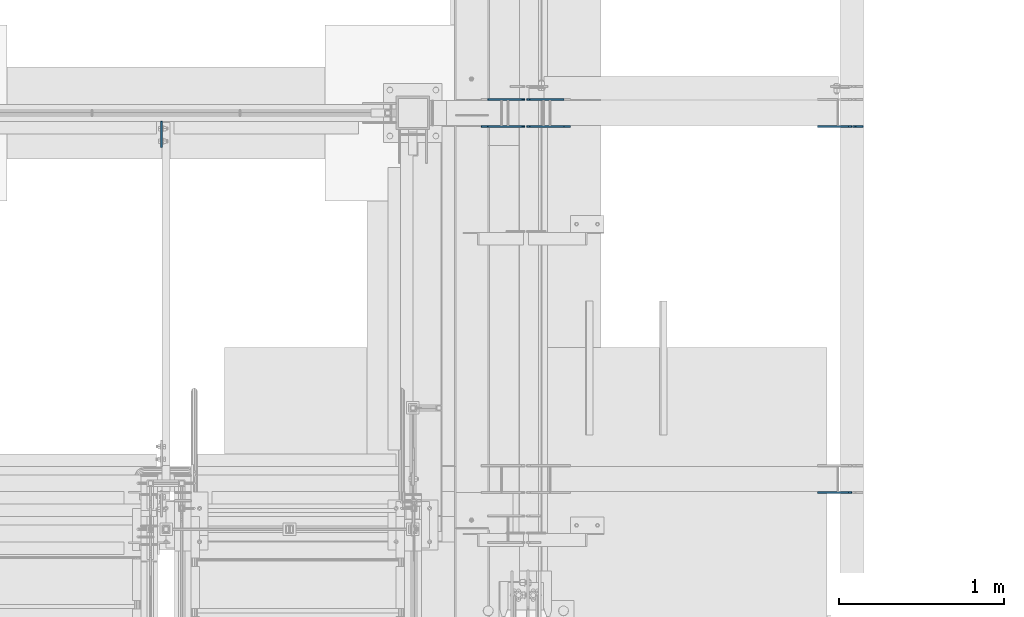
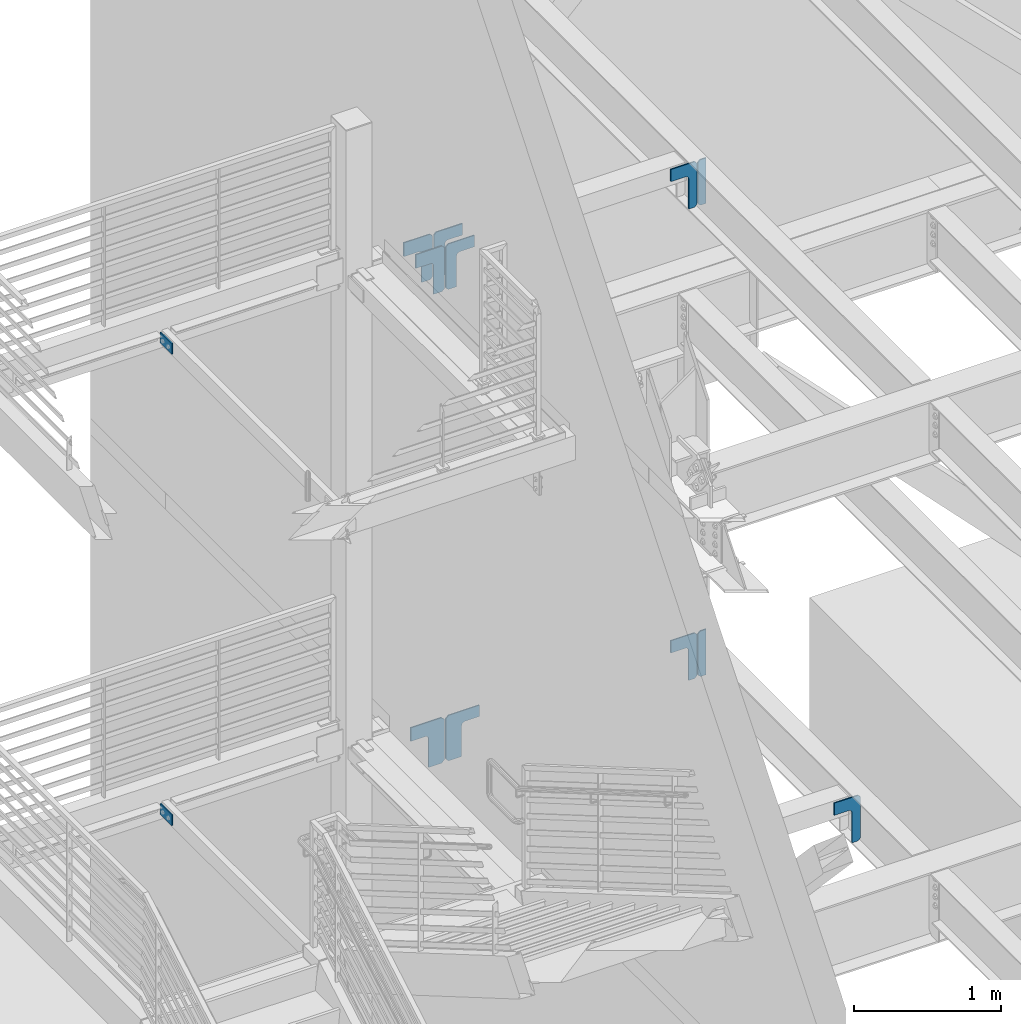
# One storey, part 1061 of 1179: 13 plates, 8 elements without a shape of their own.
"""IFC2X3 building model written with IfcOpenShell, lengths in millimetres."""

import ifcopenshell
import ifcopenshell.guid

model = None  # the IFC model being written
_history = None  # IfcOwnerHistory: only IFC2X3 demands one
_inside = {}  # id of a spatial element -> (the spatial element, [elements in it])
_under = {}  # id of a project, library or spatial element -> (it, [spatial elements below it])
_declared = {}  # id of a project -> (the project, [libraries it declares])
_typed = {}  # id of a type object -> (the type object, [elements of that type])
_made_of = {}  # id of a material, layer set ... -> (it, [elements and type objects made of it])


def new_model(schema):
    """Start an empty IFC model of exactly this schema.

    Asked for "IFC4X3", IfcOpenShell would pick the latest addendum, in which some entities
    have other attributes; the version numbers below select the first issue.
    IFC2X3 requires an IfcOwnerHistory on every rooted entity: one is made here for all.
    """
    global model, _history
    if schema == "IFC4X3":
        model = ifcopenshell.file(schema_version=(4, 3, 0, 0))
    else:
        model = ifcopenshell.file(schema=schema)
    _inside.clear()
    _under.clear()
    _declared.clear()
    _typed.clear()
    _made_of.clear()
    _history = None
    if model.schema == "IFC2X3":
        org = make("IfcOrganization", Name="unknown")
        user = make(
            "IfcPersonAndOrganization",
            ThePerson=make("IfcPerson", FamilyName="unknown"),
            TheOrganization=org,
        )
        app = make(
            "IfcApplication",
            ApplicationDeveloper=org,
            Version="unknown",
            ApplicationFullName="unknown",
            ApplicationIdentifier="unknown",
        )
        _history = make(
            "IfcOwnerHistory",
            OwningUser=user,
            OwningApplication=app,
            ChangeAction="ADDED",
            CreationDate=0,
        )
    return model


def make(cls, **values):
    """One entity of the class cls with the attributes given. An attribute that is None is left unset."""
    return model.create_entity(
        cls, **{name: value for name, value in values.items() if value is not None}
    )


def rooted(cls, **values):
    """An entity with a GlobalId (a new one), such as an element, a storey or a relation."""
    return make(cls, GlobalId=ifcopenshell.guid.new(), OwnerHistory=_history, **values)


def si_unit(unit_type, name, prefix=None):
    """IfcSIUnit, for example si_unit("LENGTHUNIT", "METRE", prefix="MILLI")."""
    return make("IfcSIUnit", UnitType=unit_type, Prefix=prefix, Name=name)


def assignment(units):
    """IfcUnitAssignment: the units of a project."""
    return None if units is None else make("IfcUnitAssignment", Units=units)


def point(xyz):
    """IfcCartesianPoint."""
    return None if xyz is None else make("IfcCartesianPoint", Coordinates=xyz)


def direction(xyz):
    """IfcDirection."""
    return None if xyz is None else make("IfcDirection", DirectionRatios=xyz)


def frame(location, z_axis=None, x_axis=None):
    """IfcAxis2Placement3D, a coordinate frame: its origin and axes. An axis left out is left unset."""
    return make(
        "IfcAxis2Placement3D",
        Location=point(location),
        Axis=direction(z_axis),
        RefDirection=direction(x_axis),
    )


def origin_with_axes():
    """The frame at (0, 0, 0) with the z axis (0, 0, 1) and the x axis (1, 0, 0) written out."""
    return frame((0.0, 0.0, 0.0), z_axis=(0.0, 0.0, 1.0), x_axis=(1.0, 0.0, 0.0))


def place(relative_to, where):
    """IfcLocalPlacement: puts the frame where relative to a parent placement (None: the world)."""
    return make(
        "IfcLocalPlacement", PlacementRelTo=relative_to, RelativePlacement=where
    )


def context(
    kind, dimensions, precision=None, world=None, true_north=None, identifier=None
):
    """IfcGeometricRepresentationContext, for example the 3D "Model" context."""
    return make(
        "IfcGeometricRepresentationContext",
        ContextIdentifier=identifier,
        ContextType=kind,
        CoordinateSpaceDimension=dimensions,
        Precision=precision,
        WorldCoordinateSystem=world,
        TrueNorth=true_north,
    )


def subcontext(parent, identifier, kind, view, scale=None):
    """IfcGeometricRepresentationSubContext, for example "Body" below "Model"."""
    return make(
        "IfcGeometricRepresentationSubContext",
        ContextIdentifier=identifier,
        ContextType=kind,
        ParentContext=parent,
        TargetScale=scale,
        TargetView=view,
    )


def project(units=None, contexts=None):
    """IfcProject with its units and contexts."""
    return rooted(
        "IfcProject",
        Name="project",
        RepresentationContexts=contexts,
        UnitsInContext=assignment(units),
    )


def spatial(cls, under=None, at=None, **own):
    """A site, building, storey or space (cls), placed at a placement, below another one or the project."""
    s = rooted(cls, ObjectPlacement=at, **own)
    if under is not None:
        _under.setdefault(under.id(), (under, []))[1].append(s)
    return s


def faces_of(points, faces, orient=None, outer=None):
    """IfcFace entities. A face is a list of loops; a loop is a list of indices into points, from 0.

    orient and outer hold one flag for each loop. By default every Orientation is true, the
    first loop of a face is its IfcFaceOuterBound and the others are IfcFaceBound.
    """
    made = []
    for i, loops in enumerate(faces):
        bounds = []
        for j, loop in enumerate(loops):
            is_outer = j == 0 if outer is None else outer[i][j]
            bounds.append(
                make(
                    "IfcFaceOuterBound" if is_outer else "IfcFaceBound",
                    Bound=make("IfcPolyLoop", Polygon=[points[k] for k in loop]),
                    Orientation=True if orient is None else orient[i][j],
                )
            )
        made.append(make("IfcFace", Bounds=bounds))
    return made


def faceted_brep(points, faces, orient=None, outer=None, voids=None):
    """IfcFacetedBrep: a solid bounded by flat faces; with voids (closed shells), ...WithVoids."""
    shared = [point(p) for p in points]
    hull = make("IfcClosedShell", CfsFaces=faces_of(shared, faces, orient, outer))
    if voids is None:
        return make("IfcFacetedBrep", Outer=hull)
    return make(
        "IfcFacetedBrepWithVoids",
        Outer=hull,
        Voids=[
            make(cls, CfsFaces=faces_of(shared, fs, o, b)) for cls, fs, o, b in voids
        ],
    )


def shape(context_of_items, identifier, shape_type, items):
    """IfcShapeRepresentation: the items that make up one representation, for example the "Body"."""
    return make(
        "IfcShapeRepresentation",
        ContextOfItems=context_of_items,
        RepresentationIdentifier=identifier,
        RepresentationType=shape_type,
        Items=items,
    )


def material(Name=None, Category=None):
    """IfcMaterial."""
    return make("IfcMaterial", Name=Name, Category=Category)


def made_of(thing, what):
    """Note that an element or type object is made of a material, layer set ...; save() writes the relation."""
    if what is not None:
        _made_of.setdefault(what.id(), (what, []))[1].append(thing)
    return thing


def type_object(cls, material=None, **own):
    """A type object (cls), such as IfcWallType, which elements share."""
    return made_of(rooted(cls, **own), material)


def element(
    cls,
    number,
    at=None,
    inside=None,
    cuts=None,
    type_object=None,
    material=None,
    context=None,
    identifier="Body",
    shape_type=None,
    held_by="IfcProductDefinitionShape",
    body=None,
    shapes=None,
    **own,
):
    """One element of the class cls, such as IfcWall. Its Tag is "e" and its number.

    at: its placement. inside: the storey or other place that contains it. cuts: it is an
    opening in that element (IfcRelVoidsElement). A single representation is given by context,
    identifier, shape_type and body (its items); several are given by shapes. held_by: the class
    of the entity that holds the representations. save() writes the other relations.
    """
    e = rooted(cls, Tag="e%d" % number, ObjectPlacement=at, **own)
    if body is not None:
        shapes = [shape(context, identifier, shape_type, body)]
    if shapes is not None:
        e.Representation = make(held_by, Representations=shapes)
    if inside is not None:
        _inside.setdefault(inside.id(), (inside, []))[1].append(e)
    if cuts is not None:
        rooted(
            "IfcRelVoidsElement", RelatingBuildingElement=cuts, RelatedOpeningElement=e
        )
    if type_object is not None:
        _typed.setdefault(type_object.id(), (type_object, []))[1].append(e)
    return made_of(e, material)


def aggregate(whole, parts):
    """IfcRelAggregates: a whole, such as a stair, and the parts it consists of."""
    return rooted("IfcRelAggregates", RelatingObject=whole, RelatedObjects=parts)


def save(model, path):
    """Write the relations noted so far, then the file.

    IfcRelAggregates (storeys below a building ...), IfcRelContainedInSpatialStructure (elements
    in a storey), IfcRelDefinesByType, IfcRelAssociatesMaterial and IfcRelDeclares: one each for
    every whole, place, type object, material and project.
    """
    for whole, parts in _under.values():
        aggregate(whole, parts)
    for where, things in _inside.values():
        rooted(
            "IfcRelContainedInSpatialStructure",
            RelatedElements=things,
            RelatingStructure=where,
        )
    for kind, things in _typed.values():
        rooted("IfcRelDefinesByType", RelatedObjects=things, RelatingType=kind)
    for what, things in _made_of.values():
        rooted("IfcRelAssociatesMaterial", RelatedObjects=things, RelatingMaterial=what)
    for by, libraries in _declared.values():
        rooted("IfcRelDeclares", RelatingContext=by, RelatedDefinitions=libraries)
    model.write(path)


model = new_model("IFC2X3")

# Units and contexts
model_context = context("Model", 3, precision=1e-05, world=origin_with_axes())
body_context = subcontext(model_context, "Body", "Model", "MODEL_VIEW")
ifc_project = project(units=[si_unit("LENGTHUNIT", "METRE", prefix="MILLI"), si_unit("AREAUNIT", "SQUARE_METRE"), si_unit("VOLUMEUNIT", "CUBIC_METRE"), si_unit("MASSUNIT", "GRAM", prefix="KILO"), si_unit("TIMEUNIT", "SECOND"), si_unit("PLANEANGLEUNIT", "RADIAN"), si_unit("SOLIDANGLEUNIT", "STERADIAN"), si_unit("THERMODYNAMICTEMPERATUREUNIT", "DEGREE_CELSIUS"), si_unit("LUMINOUSINTENSITYUNIT", "LUMEN")], contexts=[model_context])

# Site, building, storey
site_placement = place(None, origin_with_axes())
site = spatial("IfcSite", under=ifc_project, at=site_placement, CompositionType="ELEMENT")
building_placement = place(site_placement, origin_with_axes())
building = spatial("IfcBuilding", under=site, at=building_placement, Name="Undefined", CompositionType="ELEMENT")
storey_placement = place(building_placement, origin_with_axes())
storey = spatial("IfcBuildingStorey", under=building, at=storey_placement, Name="Undefined", CompositionType="ELEMENT", Elevation=0.0)

# Assembly, plate
assembly_1_placement = place(storey_placement, origin_with_axes())
assembly_1 = element("IfcElementAssembly", 1, at=assembly_1_placement, inside=storey, Name="BEAM", AssemblyPlace="NOTDEFINED", PredefinedType="RIGID_FRAME")
ifc_material = material(Name="STEEL/A36")
plate_type_1 = type_object("IfcPlateType", PredefinedType="NOTDEFINED")
plate_1_placement = place(assembly_1_placement, frame((-1781.175, 37592.0, 4114.8), z_axis=(0.0, -1.0, 0.0), x_axis=(0.0, 0.0, -1.0)))
plate_1 = element("IfcPlate", 2, at=plate_1_placement, type_object=plate_type_1, material=ifc_material, Name="PLATE", context=body_context, shape_type="Brep", body=[
    faceted_brep([(0.0, -4.76249999999709, 0.0), (0.0, -4.76250000000005, 158.75), (0.0, 4.76250000000005, 158.75), (0.0, 4.76249999999709, 0.0), (88.8999999999996, -4.76250000000005, 158.75), (88.8999999999996, 4.76250000000005, 158.75), (88.8999999999996, -4.76250000000005, 0.0), (88.8999999999996, 4.76250000000005, 0.0)], [[[0, 1, 2, 3]], [[1, 4, 5, 2]], [[4, 6, 7, 5]], [[6, 0, 3, 7]], [[5, 7, 3, 2]], [[6, 4, 1, 0]]]),
])
aggregate(assembly_1, [plate_1])

assembly_2_placement = place(storey_placement, origin_with_axes())
assembly_2 = element("IfcElementAssembly", 3, at=assembly_2_placement, inside=storey, Name="BEAM", AssemblyPlace="NOTDEFINED", PredefinedType="RIGID_FRAME")
plate_2_placement = place(assembly_2_placement, frame((-1781.175, 37592.0, 8026.4), z_axis=(0.0, -1.0, 0.0), x_axis=(0.0, 0.0, -1.0)))
plate_2 = element("IfcPlate", 4, at=plate_2_placement, type_object=plate_type_1, material=ifc_material, Name="PLATE", context=body_context, shape_type="Brep", body=[
    faceted_brep([(0.0, -4.76249999999709, 0.0), (0.0, -4.76250000000005, 158.75), (0.0, 4.76250000000005, 158.75), (0.0, 4.76249999999709, 0.0), (88.8999999999996, -4.76250000000005, 158.75), (88.8999999999996, 4.76250000000005, 158.75), (88.8999999999996, -4.76250000000005, 0.0), (88.8999999999996, 4.76250000000005, 0.0)], [[[0, 1, 2, 3]], [[1, 4, 5, 2]], [[4, 6, 7, 5]], [[6, 0, 3, 7]], [[5, 7, 3, 2]], [[6, 4, 1, 0]]]),
])
aggregate(assembly_2, [plate_2])

assembly_3_placement = place(storey_placement, origin_with_axes())
assembly_3 = element("IfcElementAssembly", 5, at=assembly_3_placement, inside=storey, Name="BEAM", AssemblyPlace="NOTDEFINED", PredefinedType="RIGID_FRAME")
plate_type_2 = type_object("IfcPlateType", PredefinedType="NOTDEFINED")
plate_3_placement = place(assembly_3_placement, frame((2481.2625, 37561.8375, 7623.175), z_axis=(0.0, 0.0, 1.0), x_axis=(-1.0, 0.0, 0.0)))
plate_3 = element("IfcPlate", 6, at=plate_3_placement, type_object=plate_type_2, material=ifc_material, Name="PLATE", context=body_context, shape_type="Brep", body=[
    faceted_brep([(0.0, -4.76249999999709, 0.0), (0.0, -4.76249999999709, 377.825012207031), (0.0, 4.76249999999709, 377.825012207031), (0.0, 4.76249999999709, 0.0), (46.0375022888184, -4.76249999999709, 377.825012207031), (46.0375022888184, 4.76249999999709, 377.825012207031), (65.0875015258789, -4.76249999999709, 358.775012969971), (65.0875015258789, 4.76249999999709, 358.775012969971), (65.0875015258789, -4.76249999999709, 19.0499992370605), (65.0875015258789, 4.76249999999709, 19.0499992370605), (46.0375022888184, -4.76249999999709, 0.0), (46.0375022888184, 4.76249999999709, 0.0)], [[[0, 1, 2, 3]], [[1, 4, 5, 2]], [[4, 6, 7, 5]], [[6, 8, 9, 7]], [[8, 10, 11, 9]], [[10, 0, 3, 11]], [[5, 7, 9, 11, 3, 2]], [[10, 8, 6, 4, 1, 0]]]),
])

assembly_4_placement = place(storey_placement, origin_with_axes())
assembly_4 = element("IfcElementAssembly", 7, at=assembly_4_placement, inside=storey, Name="BEAM", AssemblyPlace="NOTDEFINED", PredefinedType="RIGID_FRAME")
plate_4_placement = place(assembly_4_placement, frame((2481.26227437875, 37561.837550128, 3711.575), z_axis=(0.0, 0.0, 1.0), x_axis=(-1.0, 0.0, 0.0)))
plate_4 = element("IfcPlate", 8, at=plate_4_placement, type_object=plate_type_2, material=ifc_material, Name="PLATE", context=body_context, shape_type="Brep", body=[
    faceted_brep([(0.0, -4.76249999999709, 0.0), (0.0, -4.76249999999709, 377.825012207031), (0.0, 4.76249999999709, 377.825012207031), (0.0, 4.76249999999709, 0.0), (46.0375022888184, -4.76249999999709, 377.825012207031), (46.0375022888184, 4.76249999999709, 377.825012207031), (65.0875015258789, -4.76249999999709, 358.775012969971), (65.0875015258789, 4.76249999999709, 358.775012969971), (65.0875015258789, -4.76249999999709, 19.0499992370605), (65.0875015258789, 4.76249999999709, 19.0499992370605), (46.0375022888184, -4.76249999999709, 0.0), (46.0375022888184, 4.76249999999709, 0.0)], [[[0, 1, 2, 3]], [[1, 4, 5, 2]], [[4, 6, 7, 5]], [[6, 8, 9, 7]], [[8, 10, 11, 9]], [[10, 0, 3, 11]], [[5, 7, 9, 11, 3, 2]], [[10, 8, 6, 4, 1, 0]]]),
])

assembly_5_placement = place(storey_placement, origin_with_axes())
assembly_5 = element("IfcElementAssembly", 9, at=assembly_5_placement, inside=storey, Name="BEAM", AssemblyPlace="NOTDEFINED", PredefinedType="RIGID_FRAME")
plate_type_3 = type_object("IfcPlateType", PredefinedType="NOTDEFINED")
plate_5_placement = place(assembly_5_placement, frame((426.291860782883, 37561.8375048772, 7994.65), z_axis=(-1.0, 0.0, 0.0), x_axis=(0.0, 0.0, -1.0)))
plate_5 = element("IfcPlate", 10, at=plate_5_placement, type_object=plate_type_3, material=ifc_material, Name="PLATE", context=body_context, shape_type="Brep", body=[
    faceted_brep([(0.0, -4.76250000000073, 19.0499992370605), (5.15311512572225e-07, -4.76250000051368, 224.679358085698), (5.15311512572225e-07, 4.7624999994805, 224.679358085698), (0.0, 4.76250000000073, 19.0499992370605), (114.300004602274, -4.76250000051368, 224.679358106336), (114.300004602274, 4.7624999994805, 224.679358106337), (114.300004180656, -4.76250000025175, 110.379356465598), (114.300004180656, 4.76249999974243, 110.379356465598), (116.23346399875, -4.76250000022992, 100.659197401194), (116.23346399875, 4.76249999977153, 100.659197401194), (121.739491792959, -4.76250000021537, 92.4188444333355), (121.739491792959, 4.76249999978609, 92.4188444333356), (129.979844740076, -4.76250000020082, 86.9128166080852), (129.979844740076, 4.76249999980064, 86.9128166080853), (139.700003797197, -4.76250000019354, 84.9793567533749), (139.700003797197, 4.76249999980791, 84.979356753375), (377.825000000001, -4.76250000019354, 84.9793567347261), (377.825000000001, 4.76249999980791, 84.9793567347261), (377.825000000001, -4.76250000004802, 19.0499992370604), (377.825000000001, 4.76249999995343, 19.0499992370605), (358.77500076294, -4.76249999999709, -5.6843418860808e-14), (358.77500076294, 4.76249999999709, 0.0), (19.0499992370605, -4.76250000000073, 0.0), (19.0499992370605, 4.76250000000073, 0.0)], [[[0, 1, 2, 3]], [[1, 4, 5, 2]], [[4, 6, 7, 5]], [[6, 8, 9, 7]], [[8, 10, 11, 9]], [[10, 12, 13, 11]], [[12, 14, 15, 13]], [[14, 16, 17, 15]], [[16, 18, 19, 17]], [[18, 20, 21, 19]], [[20, 22, 23, 21]], [[22, 0, 3, 23]], [[5, 7, 9, 11, 13, 15, 17, 19, 21, 23, 3, 2]], [[22, 20, 18, 16, 14, 12, 10, 8, 6, 4, 1, 0]]]),
])

assembly_6_placement = place(storey_placement, origin_with_axes())
assembly_6 = element("IfcElementAssembly", 11, at=assembly_6_placement, inside=storey, Name="PLATE", AssemblyPlace="NOTDEFINED", PredefinedType="RIGID_FRAME")
plate_6_placement = place(assembly_6_placement, frame((426.291856734724, 37723.7625062674, 7994.65), z_axis=(-1.0, 0.0, 0.0), x_axis=(0.0, 0.0, -1.0)))
plate_6 = element("IfcPlate", 12, at=plate_6_placement, type_object=plate_type_3, material=ifc_material, Name="PLATE", context=body_context, shape_type="Brep", body=[
    faceted_brep([(0.0, -4.76250000000073, 19.0499992370605), (5.15311512572225e-07, -4.76250000051368, 224.679358085698), (5.15311512572225e-07, 4.7624999994805, 224.679358085698), (0.0, 4.76250000000073, 19.0499992370605), (114.300004602274, -4.76250000051368, 224.679358106336), (114.300004602274, 4.7624999994805, 224.679358106337), (114.300004180656, -4.76250000025175, 110.379356465598), (114.300004180656, 4.76249999974243, 110.379356465598), (116.23346399875, -4.76250000022992, 100.659197401194), (116.23346399875, 4.76249999977153, 100.659197401194), (121.739491792959, -4.76250000021537, 92.4188444333355), (121.739491792959, 4.76249999978609, 92.4188444333356), (129.979844740076, -4.76250000020082, 86.9128166080852), (129.979844740076, 4.76249999980064, 86.9128166080853), (139.700003797197, -4.76250000019354, 84.9793567533749), (139.700003797197, 4.76249999980791, 84.979356753375), (377.825000000001, -4.76250000019354, 84.9793567347261), (377.825000000001, 4.76249999980791, 84.9793567347261), (377.825000000001, -4.76250000004802, 19.0499992370604), (377.825000000001, 4.76249999995343, 19.0499992370605), (358.77500076294, -4.76249999999709, -5.6843418860808e-14), (358.77500076294, 4.76249999999709, 0.0), (19.0499992370605, -4.76250000000073, 0.0), (19.0499992370605, 4.76250000000073, 0.0)], [[[0, 1, 2, 3]], [[1, 4, 5, 2]], [[4, 6, 7, 5]], [[6, 8, 9, 7]], [[8, 10, 11, 9]], [[10, 12, 13, 11]], [[12, 14, 15, 13]], [[14, 16, 17, 15]], [[16, 18, 19, 17]], [[18, 20, 21, 19]], [[20, 22, 23, 21]], [[22, 0, 3, 23]], [[5, 7, 9, 11, 13, 15, 17, 19, 21, 23, 3, 2]], [[22, 20, 18, 16, 14, 12, 10, 8, 6, 4, 1, 0]]]),
])
aggregate(assembly_6, [plate_6])

# Plate
plate_type_4 = type_object("IfcPlateType", PredefinedType="NOTDEFINED")
plate_7_placement = place(assembly_3_placement, frame((2409.82498379572, 37561.8375017815, 8001.00000000008), z_axis=(-1.0, 0.0, 0.0), x_axis=(0.0, 0.0, -1.0)))
plate_7 = element("IfcPlate", 13, at=plate_7_placement, type_object=plate_type_4, material=ifc_material, Name="PLATE", context=body_context, shape_type="Brep", body=[
    faceted_brep([(0.0, -4.76250000000073, 19.0499992370605), (-8.85103781911312e-06, -4.76249999937863, 206.374999999996), (-8.85103781911312e-06, 4.76250000062282, 206.374999999998), (0.0, 4.76250000000073, 19.0499992370605), (101.599991149047, -4.76249999937863, 206.374988153153), (101.599991149047, 4.76250000062282, 206.374988153154), (101.599996121318, -4.76249999972788, 90.4391494538145), (101.599996121318, 4.76250000027358, 90.4391494538158), (103.533456383373, -4.76249999975698, 80.7189905006458), (103.533456383373, 4.76250000024447, 80.7189905006471), (109.039484537743, -4.76249999977881, 72.4786378004819), (109.039484537743, 4.76250000021537, 72.4786378004833), (117.279837710194, -4.76249999980064, 66.9726103529388), (117.279837710194, 4.76250000020082, 66.9726103529401), (126.999996829208, -4.76249999980791, 65.0391509246429), (126.999996829208, 4.76250000019354, 65.0391509246438), (377.824997210678, -4.76249999980791, 65.0391616820557), (377.824997210678, 4.76250000019354, 65.0391616820571), (377.825000000001, -4.76250000004802, 19.0499992370604), (377.825000000001, 4.76249999995343, 19.0499992370605), (358.77500076294, -4.76249999999709, -5.6843418860808e-14), (358.77500076294, 4.76249999999709, 0.0), (19.0499992370605, -4.76250000000073, 0.0), (19.0499992370605, 4.76250000000073, 0.0)], [[[0, 1, 2, 3]], [[1, 4, 5, 2]], [[4, 6, 7, 5]], [[6, 8, 9, 7]], [[8, 10, 11, 9]], [[10, 12, 13, 11]], [[12, 14, 15, 13]], [[14, 16, 17, 15]], [[16, 18, 19, 17]], [[18, 20, 21, 19]], [[20, 22, 23, 21]], [[22, 0, 3, 23]], [[5, 7, 9, 11, 13, 15, 17, 19, 21, 23, 3, 2]], [[22, 20, 18, 16, 14, 12, 10, 8, 6, 4, 1, 0]]]),
])

aggregate(assembly_3, [plate_3, plate_7])

plate_8_placement = place(assembly_4_placement, frame((2409.82471659982, 35339.337465915, 4089.4), z_axis=(-1.0, 0.0, 0.0), x_axis=(0.0, 0.0, -1.0)))
plate_8 = element("IfcPlate", 14, at=plate_8_placement, type_object=plate_type_4, material=ifc_material, Name="PLATE", context=body_context, shape_type="Brep", body=[
    faceted_brep([(0.0, -4.76250000000073, 19.0499992370605), (-8.85103781911312e-06, -4.76249999937863, 206.374999999996), (-8.85103781911312e-06, 4.76250000062282, 206.374999999998), (0.0, 4.76250000000073, 19.0499992370605), (101.599991149047, -4.76249999937863, 206.374988153153), (101.599991149047, 4.76250000062282, 206.374988153154), (101.6, -4.76249999970605, 92.0266613006611), (101.6, 4.7625000002954, 92.0266613006606), (103.533459845175, -4.76249999973516, 82.3065022645701), (103.533459845175, 4.7625000002663, 82.3065022645692), (109.039487646132, -4.76249999976426, 74.0661493282628), (109.039487646132, 4.7625000002372, 74.0661493282619), (117.279840582439, -4.76249999977881, 68.5601215273068), (117.279840582439, 4.76250000022264, 68.5601215273059), (126.99999961853, -4.76249999978609, 66.6266616821308), (126.99999961853, 4.76250000021537, 66.6266616821304), (377.825, -4.76249999978609, 66.6266616821308), (377.825, 4.76250000021537, 66.6266616821304), (377.825000000001, -4.76250000004802, 19.0499992370604), (377.825000000001, 4.76249999995343, 19.0499992370605), (358.77500076294, -4.76249999999709, -5.6843418860808e-14), (358.77500076294, 4.76249999999709, 0.0), (19.0499992370605, -4.76250000000073, 0.0), (19.0499992370605, 4.76250000000073, 0.0)], [[[0, 1, 2, 3]], [[1, 4, 5, 2]], [[4, 6, 7, 5]], [[6, 8, 9, 7]], [[8, 10, 11, 9]], [[10, 12, 13, 11]], [[12, 14, 15, 13]], [[14, 16, 17, 15]], [[16, 18, 19, 17]], [[18, 20, 21, 19]], [[20, 22, 23, 21]], [[22, 0, 3, 23]], [[5, 7, 9, 11, 13, 15, 17, 19, 21, 23, 3, 2]], [[22, 20, 18, 16, 14, 12, 10, 8, 6, 4, 1, 0]]]),
])

plate_9_placement = place(assembly_4_placement, frame((2409.82477437814, 37561.837551232, 4089.4), z_axis=(-1.0, 0.0, 0.0), x_axis=(0.0, 0.0, -1.0)))
plate_9 = element("IfcPlate", 15, at=plate_9_placement, type_object=plate_type_4, material=ifc_material, Name="PLATE", context=body_context, shape_type="Brep", body=[
    faceted_brep([(0.0, -4.76250000000073, 19.0499992370605), (0.0, -4.76249999934225, 206.451200000005), (0.0, 4.7625000006592, 206.451200000005), (0.0, 4.76250000000073, 19.0499992370605), (101.600000000002, -4.76249999934225, 206.451212629871), (101.600000000002, 4.7625000006592, 206.451212629871), (101.6, -4.76249999970605, 92.0266613006611), (101.6, 4.7625000002954, 92.0266613006606), (103.533459845175, -4.76249999973516, 82.3065022645701), (103.533459845175, 4.7625000002663, 82.3065022645692), (109.039487646132, -4.76249999976426, 74.0661493282628), (109.039487646132, 4.7625000002372, 74.0661493282619), (117.279840582439, -4.76249999977881, 68.5601215273068), (117.279840582439, 4.76250000022264, 68.5601215273059), (126.99999961853, -4.76249999978609, 66.6266616821308), (126.99999961853, 4.76250000021537, 66.6266616821304), (377.825, -4.76249999978609, 66.6266616821308), (377.825, 4.76250000021537, 66.6266616821304), (377.825000000001, -4.76250000004802, 19.0499992370604), (377.825000000001, 4.76249999995343, 19.0499992370605), (358.77500076294, -4.76249999999709, -5.6843418860808e-14), (358.77500076294, 4.76249999999709, 0.0), (19.0499992370605, -4.76250000000073, 0.0), (19.0499992370605, 4.76250000000073, 0.0)], [[[0, 1, 2, 3]], [[1, 4, 5, 2]], [[4, 6, 7, 5]], [[6, 8, 9, 7]], [[8, 10, 11, 9]], [[10, 12, 13, 11]], [[12, 14, 15, 13]], [[14, 16, 17, 15]], [[16, 18, 19, 17]], [[18, 20, 21, 19]], [[20, 22, 23, 21]], [[22, 0, 3, 23]], [[5, 7, 9, 11, 13, 15, 17, 19, 21, 23, 3, 2]], [[22, 20, 18, 16, 14, 12, 10, 8, 6, 4, 1, 0]]]),
])

aggregate(assembly_4, [plate_4, plate_8, plate_9])

plate_type_5 = type_object("IfcPlateType", PredefinedType="NOTDEFINED")
plate_10_placement = place(assembly_5_placement, frame((437.356396365306, 37561.8375017811, 7994.65), z_axis=(1.0, 0.0, 0.0), x_axis=(0.0, 0.0, -1.0)))
plate_10 = element("IfcPlate", 16, at=plate_10_placement, type_object=plate_type_5, material=ifc_material, Name="PLATE", context=body_context, shape_type="Brep", body=[
    faceted_brep([(0.0, -4.76250000000073, 19.0499992370605), (0.0, -4.76249999977153, 224.631103634694), (0.0, 4.76250000022992, 224.631103634695), (0.0, 4.76250000000073, 19.0499992370605), (95.25, -4.76249999977153, 224.631103634694), (95.25, 4.76250000022992, 224.631103634695), (95.25, -4.76249999988795, 110.331103253224), (95.25, 4.76250000010623, 110.331103253225), (97.183459845176, -4.7624999999025, 100.610944217133), (97.183459845176, 4.76250000009895, 100.610944217134), (102.689487646132, -4.7624999999025, 92.370591280826), (102.689487646132, 4.76250000009168, 92.3705912808262), (110.929840582439, -4.76249999991705, 86.8645634798699), (110.929840582439, 4.7625000000844, 86.86456347987), (120.64999961853, -4.76249999991705, 84.9311036346941), (120.64999961853, 4.7625000000844, 84.9311036346945), (377.825000000001, -4.76249999991705, 84.9311036346941), (377.825000000001, 4.7625000000844, 84.9311036346945), (377.825000000001, -4.76250000004802, 19.0499992370604), (377.825000000001, 4.76249999995343, 19.0499992370605), (358.77500076294, -4.76249999999709, -5.6843418860808e-14), (358.77500076294, 4.76249999999709, 0.0), (19.0499992370605, -4.76250000000073, 0.0), (19.0499992370605, 4.76250000000073, 0.0)], [[[0, 1, 2, 3]], [[1, 4, 5, 2]], [[4, 6, 7, 5]], [[6, 8, 9, 7]], [[8, 10, 11, 9]], [[10, 12, 13, 11]], [[12, 14, 15, 13]], [[14, 16, 17, 15]], [[16, 18, 19, 17]], [[18, 20, 21, 19]], [[20, 22, 23, 21]], [[22, 0, 3, 23]], [[5, 7, 9, 11, 13, 15, 17, 19, 21, 23, 3, 2]], [[22, 20, 18, 16, 14, 12, 10, 8, 6, 4, 1, 0]]]),
])

aggregate(assembly_5, [plate_5, plate_10])

# Assembly, plate
assembly_7_placement = place(storey_placement, origin_with_axes())
assembly_7 = element("IfcElementAssembly", 17, at=assembly_7_placement, inside=storey, Name="PLATE", AssemblyPlace="NOTDEFINED", PredefinedType="RIGID_FRAME")
plate_11_placement = place(assembly_7_placement, frame((437.356396365304, 37723.7625031713, 7994.65), z_axis=(1.0, 0.0, 0.0), x_axis=(0.0, 0.0, -1.0)))
plate_11 = element("IfcPlate", 18, at=plate_11_placement, type_object=plate_type_5, material=ifc_material, Name="PLATE", context=body_context, shape_type="Brep", body=[
    faceted_brep([(0.0, -4.76250000000073, 19.0499992370605), (0.0, -4.76249999977153, 224.631103634694), (0.0, 4.76250000022992, 224.631103634695), (0.0, 4.76250000000073, 19.0499992370605), (95.25, -4.76249999977153, 224.631103634694), (95.25, 4.76250000022992, 224.631103634695), (95.25, -4.76249999988795, 110.331103253224), (95.25, 4.76250000010623, 110.331103253225), (97.183459845176, -4.7624999999025, 100.610944217133), (97.183459845176, 4.76250000009895, 100.610944217134), (102.689487646132, -4.7624999999025, 92.370591280826), (102.689487646132, 4.76250000009168, 92.3705912808262), (110.929840582439, -4.76249999991705, 86.8645634798699), (110.929840582439, 4.7625000000844, 86.86456347987), (120.64999961853, -4.76249999991705, 84.9311036346941), (120.64999961853, 4.7625000000844, 84.9311036346945), (377.825000000001, -4.76249999991705, 84.9311036346941), (377.825000000001, 4.7625000000844, 84.9311036346945), (377.825000000001, -4.76250000004802, 19.0499992370604), (377.825000000001, 4.76249999995343, 19.0499992370605), (358.77500076294, -4.76249999999709, -5.6843418860808e-14), (358.77500076294, 4.76249999999709, 0.0), (19.0499992370605, -4.76250000000073, 0.0), (19.0499992370605, 4.76250000000073, 0.0)], [[[0, 1, 2, 3]], [[1, 4, 5, 2]], [[4, 6, 7, 5]], [[6, 8, 9, 7]], [[8, 10, 11, 9]], [[10, 12, 13, 11]], [[12, 14, 15, 13]], [[14, 16, 17, 15]], [[16, 18, 19, 17]], [[18, 20, 21, 19]], [[20, 22, 23, 21]], [[22, 0, 3, 23]], [[5, 7, 9, 11, 13, 15, 17, 19, 21, 23, 3, 2]], [[22, 20, 18, 16, 14, 12, 10, 8, 6, 4, 1, 0]]]),
])
aggregate(assembly_7, [plate_11])

# Assembly, plates
assembly_8_placement = place(storey_placement, origin_with_axes())
assembly_8 = element("IfcElementAssembly", 19, at=assembly_8_placement, inside=storey, Name="BEAM", AssemblyPlace="NOTDEFINED", PredefinedType="RIGID_FRAME")
plate_type_6 = type_object("IfcPlateType", PredefinedType="NOTDEFINED")
plate_12_placement = place(assembly_8_placement, frame((426.291860782883, 37561.8375016434, 4081.4625), z_axis=(-1.0, 0.0, 0.0), x_axis=(0.0, 0.0, -1.0)))
plate_12 = element("IfcPlate", 20, at=plate_12_placement, type_object=plate_type_6, material=ifc_material, Name="PLATE", context=body_context, shape_type="Brep", body=[
    faceted_brep([(0.0, -4.76250000000073, 22.2250003814697), (0.0, -4.7625000004773, 264.366903051295), (0.0, 4.76249999952415, 264.366903051295), (0.0, 4.76250000000073, 22.2250003814697), (112.7125, -4.7625000004773, 264.366903051295), (112.7125, 4.76249999952415, 264.366903051295), (112.7125, -4.76250000027358, 150.018749618534), (112.7125, 4.76249999972788, 150.018749618534), (114.645959845175, -4.76250000025175, 140.298590582443), (114.645959845175, 4.76249999974971, 140.298590582443), (120.151987646132, -4.7625000002372, 132.058237646135), (120.151987646132, 4.76249999976426, 132.058237646135), (128.392340582439, -4.76250000022992, 126.552209845179), (128.392340582439, 4.76249999976426, 126.552209845179), (138.11249961853, -4.76250000022992, 124.618750000003), (138.11249961853, 4.76249999977153, 124.618750000003), (377.825, -4.76249999973516, 124.61875), (377.825, 4.7625000002663, 124.61875), (377.825, -4.76250000004802, 22.2250003814698), (377.825, 4.76249999995343, 22.2250003814697), (355.59999961853, -4.76250000000437, 0.0), (355.59999961853, 4.76249999998981, -1.13686837721616e-13), (22.2250003814697, -4.76250000000073, 0.0), (22.2250003814697, 4.76250000000073, 0.0)], [[[0, 1, 2, 3]], [[1, 4, 5, 2]], [[4, 6, 7, 5]], [[6, 8, 9, 7]], [[8, 10, 11, 9]], [[10, 12, 13, 11]], [[12, 14, 15, 13]], [[14, 16, 17, 15]], [[16, 18, 19, 17]], [[18, 20, 21, 19]], [[20, 22, 23, 21]], [[22, 0, 3, 23]], [[5, 7, 9, 11, 13, 15, 17, 19, 21, 23, 3, 2]], [[22, 20, 18, 16, 14, 12, 10, 8, 6, 4, 1, 0]]]),
])
plate_13_placement = place(assembly_8_placement, frame((437.356170743451, 37561.83750192, 4081.4625), z_axis=(1.0, 0.0, 0.0), x_axis=(0.0, 0.0, -1.0)))
plate_13 = element("IfcPlate", 21, at=plate_13_placement, type_object=plate_type_6, material=ifc_material, Name="PLATE", context=body_context, shape_type="Brep", body=[
    faceted_brep([(0.0, -4.76250000000073, 22.2250003814697), (0.0, -4.76250000047003, 264.318756103518), (0.0, 4.76249999953143, 264.318756103518), (0.0, 4.76250000000073, 22.2250003814697), (93.6624999999999, -4.76249999943684, 264.318756103516), (93.6624999999999, 4.76250000056461, 264.318756103516), (93.6624999999999, -4.76249999967695, 150.01874961853), (93.6624999999999, 4.76250000032451, 150.01874961853), (95.5959598451755, -4.76249999969878, 140.298590582439), (95.5959598451755, 4.76250000030268, 140.298590582439), (101.101987646132, -4.76249999971333, 132.058237646132), (101.101987646132, 4.76250000028085, 132.058237646132), (109.342340582439, -4.76249999972788, 126.552209845176), (109.342340582439, 4.76250000027358, 126.552209845176), (119.06249961853, -4.76249999973516, 124.61875), (119.06249961853, 4.7625000002663, 124.61875), (377.825, -4.76249999973516, 124.61875), (377.825, 4.7625000002663, 124.61875), (377.825, -4.76250000004802, 22.2250003814698), (377.825, 4.76249999995343, 22.2250003814697), (355.59999961853, -4.76250000000437, 0.0), (355.59999961853, 4.76249999998981, -1.13686837721616e-13), (22.2250003814697, -4.76250000000073, 0.0), (22.2250003814697, 4.76250000000073, 0.0)], [[[0, 1, 2, 3]], [[1, 4, 5, 2]], [[4, 6, 7, 5]], [[6, 8, 9, 7]], [[8, 10, 11, 9]], [[10, 12, 13, 11]], [[12, 14, 15, 13]], [[14, 16, 17, 15]], [[16, 18, 19, 17]], [[18, 20, 21, 19]], [[20, 22, 23, 21]], [[22, 0, 3, 23]], [[5, 7, 9, 11, 13, 15, 17, 19, 21, 23, 3, 2]], [[22, 20, 18, 16, 14, 12, 10, 8, 6, 4, 1, 0]]]),
])
aggregate(assembly_8, [plate_12, plate_13])

save(model, "model.ifc")
